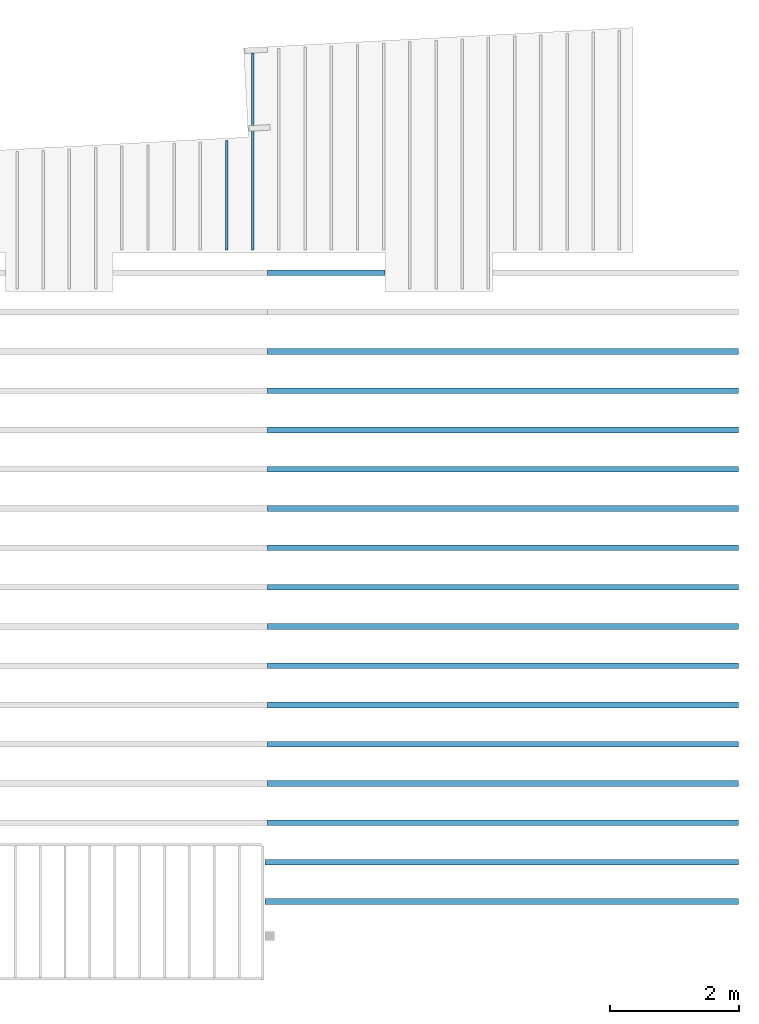
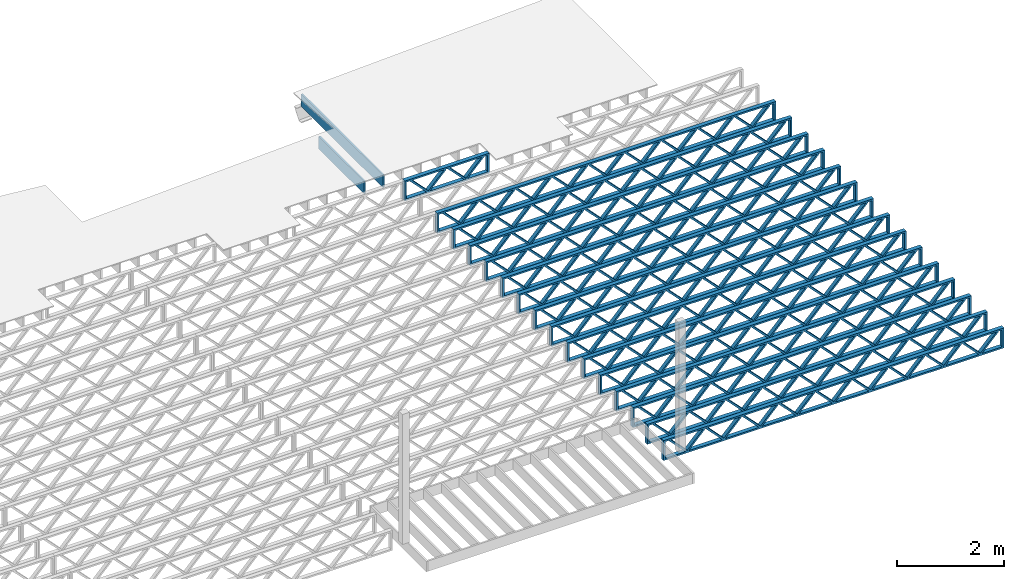
# One storey, part 11 of 13: 18 beams, 2 elements without a shape of their own.
"""IFC4 building model written with IfcOpenShell, lengths in feet."""

import ifcopenshell
import ifcopenshell.guid

model = None  # the IFC model being written
_history = None  # IfcOwnerHistory: only IFC2X3 demands one
_inside = {}  # id of a spatial element -> (the spatial element, [elements in it])
_under = {}  # id of a project, library or spatial element -> (it, [spatial elements below it])
_declared = {}  # id of a project -> (the project, [libraries it declares])
_typed = {}  # id of a type object -> (the type object, [elements of that type])
_made_of = {}  # id of a material, layer set ... -> (it, [elements and type objects made of it])


def new_model(schema):
    """Start an empty IFC model of exactly this schema.

    Asked for "IFC4X3", IfcOpenShell would pick the latest addendum, in which some entities
    have other attributes; the version numbers below select the first issue.
    IFC2X3 requires an IfcOwnerHistory on every rooted entity: one is made here for all.
    """
    global model, _history
    if schema == "IFC4X3":
        model = ifcopenshell.file(schema_version=(4, 3, 0, 0))
    else:
        model = ifcopenshell.file(schema=schema)
    _inside.clear()
    _under.clear()
    _declared.clear()
    _typed.clear()
    _made_of.clear()
    _history = None
    if model.schema == "IFC2X3":
        org = make("IfcOrganization", Name="unknown")
        user = make(
            "IfcPersonAndOrganization",
            ThePerson=make("IfcPerson", FamilyName="unknown"),
            TheOrganization=org,
        )
        app = make(
            "IfcApplication",
            ApplicationDeveloper=org,
            Version="unknown",
            ApplicationFullName="unknown",
            ApplicationIdentifier="unknown",
        )
        _history = make(
            "IfcOwnerHistory",
            OwningUser=user,
            OwningApplication=app,
            ChangeAction="ADDED",
            CreationDate=0,
        )
    return model


def make(cls, **values):
    """One entity of the class cls with the attributes given. An attribute that is None is left unset."""
    return model.create_entity(
        cls, **{name: value for name, value in values.items() if value is not None}
    )


def entity(cls, *values):
    """Any entity or typed value of the class cls, its attributes in the order of the schema. None: left unset."""
    e = model.create_entity(cls)
    for i, value in enumerate(values):
        if value is not None:
            e[i] = value
    return e


def rooted(cls, **values):
    """An entity with a GlobalId (a new one), such as an element, a storey or a relation."""
    return make(cls, GlobalId=ifcopenshell.guid.new(), OwnerHistory=_history, **values)


def si_unit(unit_type, name, prefix=None):
    """IfcSIUnit, for example si_unit("LENGTHUNIT", "METRE", prefix="MILLI")."""
    return make("IfcSIUnit", UnitType=unit_type, Prefix=prefix, Name=name)


def converted_unit(unit_type, name, factor, base, dimensions=None, offset=None):
    """IfcConversionBasedUnit, such as the inch: factor (a typed value) times the base unit."""
    return make(
        "IfcConversionBasedUnit"
        if offset is None
        else "IfcConversionBasedUnitWithOffset",
        ConversionOffset=offset,
        Dimensions=None
        if dimensions is None
        else entity("IfcDimensionalExponents", *dimensions),
        UnitType=unit_type,
        Name=name,
        ConversionFactor=make(
            "IfcMeasureWithUnit", ValueComponent=factor, UnitComponent=base
        ),
    )


def derived_unit(unit_type, elements):
    """IfcDerivedUnit: a product of units, each with its exponent."""
    return make(
        "IfcDerivedUnit",
        Elements=[
            make("IfcDerivedUnitElement", Unit=unit, Exponent=power)
            for unit, power in elements
        ],
        UnitType=unit_type,
    )


def assignment(units):
    """IfcUnitAssignment: the units of a project."""
    return None if units is None else make("IfcUnitAssignment", Units=units)


def point(xyz):
    """IfcCartesianPoint."""
    return None if xyz is None else make("IfcCartesianPoint", Coordinates=xyz)


def direction(xyz):
    """IfcDirection."""
    return None if xyz is None else make("IfcDirection", DirectionRatios=xyz)


def frame(location, z_axis=None, x_axis=None):
    """IfcAxis2Placement3D, a coordinate frame: its origin and axes. An axis left out is left unset."""
    return make(
        "IfcAxis2Placement3D",
        Location=point(location),
        Axis=direction(z_axis),
        RefDirection=direction(x_axis),
    )


def frame_2d(location, x_axis=None):
    """IfcAxis2Placement2D, a coordinate frame in the plane: its origin and x axis."""
    return make(
        "IfcAxis2Placement2D", Location=point(location), RefDirection=direction(x_axis)
    )


def origin():
    """The frame at (0, 0, 0) with its axes left unset."""
    return frame((0.0, 0.0, 0.0))


def origin_2d_with_axis():
    """The frame at (0, 0) in the plane with the x axis (1, 0) written out."""
    return frame_2d((0.0, 0.0), x_axis=(1.0, 0.0))


def place(relative_to, where):
    """IfcLocalPlacement: puts the frame where relative to a parent placement (None: the world)."""
    return make(
        "IfcLocalPlacement", PlacementRelTo=relative_to, RelativePlacement=where
    )


def context(
    kind, dimensions, precision=None, world=None, true_north=None, identifier=None
):
    """IfcGeometricRepresentationContext, for example the 3D "Model" context."""
    return make(
        "IfcGeometricRepresentationContext",
        ContextIdentifier=identifier,
        ContextType=kind,
        CoordinateSpaceDimension=dimensions,
        Precision=precision,
        WorldCoordinateSystem=world,
        TrueNorth=true_north,
    )


def subcontext(parent, identifier, kind, view, scale=None):
    """IfcGeometricRepresentationSubContext, for example "Body" below "Model"."""
    return make(
        "IfcGeometricRepresentationSubContext",
        ContextIdentifier=identifier,
        ContextType=kind,
        ParentContext=parent,
        TargetScale=scale,
        TargetView=view,
    )


def project(units=None, contexts=None):
    """IfcProject with its units and contexts."""
    return rooted(
        "IfcProject",
        Name="project",
        RepresentationContexts=contexts,
        UnitsInContext=assignment(units),
    )


def spatial(cls, under=None, at=None, **own):
    """A site, building, storey or space (cls), placed at a placement, below another one or the project."""
    s = rooted(cls, ObjectPlacement=at, **own)
    if under is not None:
        _under.setdefault(under.id(), (under, []))[1].append(s)
    return s


def profile(cls, at=None, kind="AREA", **sizes):
    """A parametric profile (cls). Its sizes go by their IFC names, for example OverallWidth=200.0."""
    return make(cls, ProfileType=kind, Position=at, **sizes)


def rectangle(**sizes):
    """IfcRectangleProfileDef."""
    return profile("IfcRectangleProfileDef", **sizes)


def extrude(swept, where, along, depth):
    """IfcExtrudedAreaSolid: the profile swept, set in the frame where, extruded along a direction by depth."""
    return make(
        "IfcExtrudedAreaSolid",
        SweptArea=swept,
        Position=where,
        ExtrudedDirection=direction(along),
        Depth=depth,
    )


def shape(context_of_items, identifier, shape_type, items):
    """IfcShapeRepresentation: the items that make up one representation, for example the "Body"."""
    return make(
        "IfcShapeRepresentation",
        ContextOfItems=context_of_items,
        RepresentationIdentifier=identifier,
        RepresentationType=shape_type,
        Items=items,
    )


def source(mapping_origin, context_of_items, identifier, shape_type, items):
    """IfcRepresentationMap: a shape defined once, which mapped items show again and again."""
    return make(
        "IfcRepresentationMap",
        MappingOrigin=mapping_origin,
        MappedRepresentation=shape(context_of_items, identifier, shape_type, items),
    )


def transform(
    local_origin,
    x_axis=None,
    y_axis=None,
    z_axis=None,
    scale=None,
    scale2=None,
    scale3=None,
    uniform=True,
):
    """IfcCartesianTransformationOperator3D, or its non-uniform kind. x_axis, y_axis, z_axis: its Axis1, 2, 3."""
    if uniform:
        return make(
            "IfcCartesianTransformationOperator3D",
            Axis1=direction(x_axis),
            Axis2=direction(y_axis),
            LocalOrigin=point(local_origin),
            Scale=scale,
            Axis3=direction(z_axis),
        )
    return make(
        "IfcCartesianTransformationOperator3DnonUniform",
        Axis1=direction(x_axis),
        Axis2=direction(y_axis),
        LocalOrigin=point(local_origin),
        Scale=scale,
        Axis3=direction(z_axis),
        Scale2=scale2,
        Scale3=scale3,
    )


def mapped(mapping_source, mapping_target):
    """IfcMappedItem: shows the shape of a source again, moved by a transform."""
    return make(
        "IfcMappedItem", MappingSource=mapping_source, MappingTarget=mapping_target
    )


def material(Name=None, Category=None):
    """IfcMaterial."""
    return make("IfcMaterial", Name=Name, Category=Category)


def material_profile(
    of_material, cross_section, Name=None, Category=None, Priority=None
):
    """IfcMaterialProfile: a cross section and its material."""
    return make(
        "IfcMaterialProfile",
        Name=Name,
        Material=of_material,
        Profile=cross_section,
        Priority=Priority,
        Category=Category,
    )


def profile_set(profiles, Name=None, composite=None):
    """IfcMaterialProfileSet."""
    return make(
        "IfcMaterialProfileSet",
        Name=Name,
        MaterialProfiles=profiles,
        CompositeProfile=composite,
    )


def profile_usage(for_profile_set, cardinal=None, extent=None):
    """IfcMaterialProfileSetUsage: how a profile set lies along its element."""
    return make(
        "IfcMaterialProfileSetUsage",
        ForProfileSet=for_profile_set,
        CardinalPoint=cardinal,
        ReferenceExtent=extent,
    )


def made_of(thing, what):
    """Note that an element or type object is made of a material, layer set ...; save() writes the relation."""
    if what is not None:
        _made_of.setdefault(what.id(), (what, []))[1].append(thing)
    return thing


def type_object(cls, material=None, **own):
    """A type object (cls), such as IfcWallType, which elements share."""
    return made_of(rooted(cls, **own), material)


def type_shapes(of_type, sources):
    """Give a type object the sources (RepresentationMaps) that its elements show as mapped items."""
    of_type.RepresentationMaps = sources


def element(
    cls,
    number,
    at=None,
    inside=None,
    cuts=None,
    type_object=None,
    material=None,
    context=None,
    identifier="Body",
    shape_type=None,
    held_by="IfcProductDefinitionShape",
    body=None,
    shapes=None,
    **own,
):
    """One element of the class cls, such as IfcWall. Its Tag is "e" and its number.

    at: its placement. inside: the storey or other place that contains it. cuts: it is an
    opening in that element (IfcRelVoidsElement). A single representation is given by context,
    identifier, shape_type and body (its items); several are given by shapes. held_by: the class
    of the entity that holds the representations. save() writes the other relations.
    """
    e = rooted(cls, Tag="e%d" % number, ObjectPlacement=at, **own)
    if body is not None:
        shapes = [shape(context, identifier, shape_type, body)]
    if shapes is not None:
        e.Representation = make(held_by, Representations=shapes)
    if inside is not None:
        _inside.setdefault(inside.id(), (inside, []))[1].append(e)
    if cuts is not None:
        rooted(
            "IfcRelVoidsElement", RelatingBuildingElement=cuts, RelatedOpeningElement=e
        )
    if type_object is not None:
        _typed.setdefault(type_object.id(), (type_object, []))[1].append(e)
    return made_of(e, material)


def aggregate(whole, parts):
    """IfcRelAggregates: a whole, such as a stair, and the parts it consists of."""
    return rooted("IfcRelAggregates", RelatingObject=whole, RelatedObjects=parts)


def save(model, path):
    """Write the relations noted so far, then the file.

    IfcRelAggregates (storeys below a building ...), IfcRelContainedInSpatialStructure (elements
    in a storey), IfcRelDefinesByType, IfcRelAssociatesMaterial and IfcRelDeclares: one each for
    every whole, place, type object, material and project.
    """
    for whole, parts in _under.values():
        aggregate(whole, parts)
    for where, things in _inside.values():
        rooted(
            "IfcRelContainedInSpatialStructure",
            RelatedElements=things,
            RelatingStructure=where,
        )
    for kind, things in _typed.values():
        rooted("IfcRelDefinesByType", RelatedObjects=things, RelatingType=kind)
    for what, things in _made_of.values():
        rooted("IfcRelAssociatesMaterial", RelatedObjects=things, RelatingMaterial=what)
    for by, libraries in _declared.values():
        rooted("IfcRelDeclares", RelatingContext=by, RelatedDefinitions=libraries)
    model.write(path)


model = new_model("IFC4")

# Units and contexts
model_context_1 = context("Model", 3, precision=0.0001, world=origin(), true_north=direction((6.12303176911189e-17, 1.0)))
model_context_2 = context("Model", 3, precision=0.0001, world=origin(), true_north=direction((6.12303176911189e-17, 1.0)))
body_context = subcontext(model_context_2, "Body", "Model", "MODEL_VIEW")
ifc_project = project(units=[converted_unit("LENGTHUNIT", "FOOT", entity("IfcRatioMeasure", 0.3048), si_unit("LENGTHUNIT", "METRE"), dimensions=[1, 0, 0, 0, 0, 0, 0]), converted_unit("AREAUNIT", "SQUARE FOOT", entity("IfcRatioMeasure", 0.09290304), si_unit("AREAUNIT", "SQUARE_METRE"), dimensions=[2, 0, 0, 0, 0, 0, 0]), converted_unit("VOLUMEUNIT", "CUBIC FOOT", entity("IfcRatioMeasure", 0.028316846592), si_unit("VOLUMEUNIT", "CUBIC_METRE"), dimensions=[3, 0, 0, 0, 0, 0, 0]), converted_unit("PLANEANGLEUNIT", "DEGREE", entity("IfcRatioMeasure", 0.0174532925199433), si_unit("PLANEANGLEUNIT", "RADIAN"), dimensions=[0, 0, 0, 0, 0, 0, 0]), si_unit("MASSUNIT", "GRAM", prefix="KILO"), derived_unit("MASSDENSITYUNIT", [(si_unit("MASSUNIT", "GRAM", prefix="KILO"), 1), (si_unit("LENGTHUNIT", "METRE"), -3)]), derived_unit("MOMENTOFINERTIAUNIT", [(si_unit("LENGTHUNIT", "METRE"), 4)]), si_unit("TIMEUNIT", "SECOND"), si_unit("FREQUENCYUNIT", "HERTZ"), si_unit("THERMODYNAMICTEMPERATUREUNIT", "DEGREE_CELSIUS"), derived_unit("THERMALTRANSMITTANCEUNIT", [(si_unit("MASSUNIT", "GRAM", prefix="KILO"), 1), (si_unit("THERMODYNAMICTEMPERATUREUNIT", "KELVIN"), -1), (si_unit("TIMEUNIT", "SECOND"), -3)]), derived_unit("VOLUMETRICFLOWRATEUNIT", [(si_unit("LENGTHUNIT", "METRE"), 3), (si_unit("TIMEUNIT", "SECOND"), -1)]), si_unit("ELECTRICCURRENTUNIT", "AMPERE"), si_unit("ELECTRICVOLTAGEUNIT", "VOLT"), si_unit("POWERUNIT", "WATT"), si_unit("FORCEUNIT", "NEWTON"), si_unit("ILLUMINANCEUNIT", "LUX"), si_unit("LUMINOUSFLUXUNIT", "LUMEN"), si_unit("LUMINOUSINTENSITYUNIT", "CANDELA"), derived_unit("USERDEFINED", [(si_unit("MASSUNIT", "GRAM", prefix="KILO"), -1), (si_unit("LENGTHUNIT", "METRE"), -2), (si_unit("TIMEUNIT", "SECOND"), 3), (si_unit("LUMINOUSFLUXUNIT", "LUMEN"), 1)]), derived_unit("LINEARVELOCITYUNIT", [(si_unit("LENGTHUNIT", "METRE"), 1), (si_unit("TIMEUNIT", "SECOND"), -1)]), si_unit("PRESSUREUNIT", "PASCAL"), derived_unit("USERDEFINED", [(si_unit("LENGTHUNIT", "METRE"), -2), (si_unit("MASSUNIT", "GRAM", prefix="KILO"), 1), (si_unit("TIMEUNIT", "SECOND"), -2)]), derived_unit("LINEARFORCEUNIT", [(si_unit("MASSUNIT", "GRAM", prefix="KILO"), 1), (si_unit("LENGTHUNIT", "METRE"), 1), (si_unit("TIMEUNIT", "SECOND"), -2), (si_unit("LENGTHUNIT", "METRE"), -1)]), derived_unit("PLANARFORCEUNIT", [(si_unit("MASSUNIT", "GRAM", prefix="KILO"), 1), (si_unit("LENGTHUNIT", "METRE"), 1), (si_unit("TIMEUNIT", "SECOND"), -2), (si_unit("LENGTHUNIT", "METRE"), -2)])], contexts=[model_context_1])

# Site, building, storey
site_placement = place(None, origin())
site = spatial("IfcSite", under=ifc_project, at=site_placement, CompositionType="ELEMENT")
building_placement = place(site_placement, origin())
building = spatial("IfcBuilding", under=site, at=building_placement, CompositionType="ELEMENT")
storey_placement = place(building_placement, frame((0.0, 0.0, 21.46875)))
storey = spatial("IfcBuildingStorey", under=building, at=storey_placement, Name="3RD FLOOR", CompositionType="ELEMENT", Elevation=21.46875)

# Assembly, beams
assembly_1_placement = place(storey_placement, origin())
assembly_1 = element("IfcElementAssembly", 1, at=assembly_1_placement, inside=storey, Name="Structural Beam System:Structural Framing System", ObjectType="Structural Beam System:Structural Framing System", AssemblyPlace="NOTDEFINED", PredefinedType="BEAM_GRID")
ifc_material_1 = material(Name="WOOD TRUSS", Category="Materials")
ifc_material_profile_1 = material_profile(ifc_material_1, rectangle(XDim=1.73473973950632, YDim=0.125, at=frame_2d((-1.11022302462516e-16, 8.32667268468867e-17), x_axis=(1.0, 0.0))))
ifc_material_profile_2 = material_profile(ifc_material_1, rectangle(XDim=1.73473973950633, YDim=0.125, at=frame_2d((-1.11022302462516e-16, 8.32667268468867e-17), x_axis=(1.0, 0.0))))
ifc_material_profile_3 = material_profile(ifc_material_1, rectangle(XDim=1.73473973950632, YDim=0.125, at=frame_2d((-5.55111512312578e-17, 1.38777878078145e-16), x_axis=(1.0, 0.0))))
ifc_material_profile_4 = material_profile(ifc_material_1, rectangle(XDim=1.73473973950633, YDim=0.125, at=frame_2d((-1.11022302462516e-16, 8.32667268468867e-17), x_axis=(1.0, 0.0))))
ifc_material_profile_5 = material_profile(ifc_material_1, rectangle(XDim=1.73473973950632, YDim=0.125, at=frame_2d((-1.11022302462516e-16, 8.32667268468867e-17), x_axis=(1.0, 0.0))))
ifc_material_profile_6 = material_profile(ifc_material_1, rectangle(XDim=1.73473973950633, YDim=0.125, at=frame_2d((-2.77555756156289e-16, 3.05311331771918e-16), x_axis=(1.0, 0.0))))
ifc_material_profile_7 = material_profile(ifc_material_1, rectangle(XDim=1.73473973950632, YDim=0.124999999999999, at=frame_2d((-3.88578058618805e-16, -2.4980018054066e-16), x_axis=(1.0, 0.0))))
ifc_material_profile_8 = material_profile(ifc_material_1, rectangle(XDim=1.73473973950633, YDim=0.125, at=frame_2d((2.77555756156289e-16, -3.05311331771918e-16), x_axis=(1.0, 0.0))))
ifc_material_profile_9 = material_profile(ifc_material_1, rectangle(XDim=1.73473973950632, YDim=0.124999999999999, at=frame_2d((-1.11022302462516e-16, 8.32667268468867e-17), x_axis=(1.0, 0.0))))
ifc_material_profile_10 = material_profile(ifc_material_1, rectangle(XDim=1.73473973950633, YDim=0.125, at=origin_2d_with_axis()))
ifc_material_profile_11 = material_profile(ifc_material_1, rectangle(XDim=0.124999999999982, YDim=0.291666666666668, at=origin_2d_with_axis()))
ifc_material_profile_12 = material_profile(ifc_material_1, rectangle(XDim=0.124999999999932, YDim=0.291666666666664, at=origin_2d_with_axis()))
ifc_material_profile_13 = material_profile(ifc_material_1, rectangle(XDim=1.25000000000002, YDim=0.29166666666667, at=origin_2d_with_axis()))
ifc_material_profile_14 = material_profile(ifc_material_1, rectangle(XDim=1.25000000000004, YDim=0.291666666666667, at=origin_2d_with_axis()))
ifc_profile_set_1 = profile_set([ifc_material_profile_1, ifc_material_profile_2, ifc_material_profile_3, ifc_material_profile_4, ifc_material_profile_5, ifc_material_profile_6, ifc_material_profile_7, ifc_material_profile_8, ifc_material_profile_9, ifc_material_profile_10, ifc_material_profile_11, ifc_material_profile_12, ifc_material_profile_13, ifc_material_profile_14])
ifc_profile_usage_1 = profile_usage(ifc_profile_set_1, cardinal=8)
beam_type_1 = type_object("IfcBeamType", PredefinedType="BEAM", material=ifc_profile_set_1)
shared_shape_1 = source(origin(), body_context, "Body", "SweptSolid", [
    extrude(rectangle(XDim=1.73473973950632, YDim=0.124999999999999, at=frame_2d((5.55111512312578e-16, 7.21644966006352e-16), x_axis=(1.0, 0.0))), frame((8.42202085580899, -0.145833333333334, 0.0), z_axis=(0.0, 1.0, 0.0), x_axis=(0.693383046997606, 0.0, 0.720569184836762)), (0.0, 0.0, 1.0), 0.291666666666667),
    extrude(rectangle(XDim=1.73473973950633, YDim=0.125, at=origin_2d_with_axis()), frame((7.17173498213572, -0.145833333333334, 0.0), z_axis=(0.0, 1.0, 0.0), x_axis=(0.69338304699761, 0.0, -0.720569184836758)), (0.0, 0.0, 1.0), 0.291666666666666),
    extrude(rectangle(XDim=1.73473973950632, YDim=0.124999999999999, at=frame_2d((-1.11022302462516e-16, 8.32667268468867e-17), x_axis=(1.0, 0.0))), frame((5.82306154948498, -0.145833333333334, 0.0), z_axis=(0.0, 1.0, 0.0), x_axis=(0.693383046997606, 0.0, 0.720569184836762)), (0.0, 0.0, 1.0), 0.291666666666667),
    extrude(rectangle(XDim=1.73473973950633, YDim=0.125, at=origin_2d_with_axis()), frame((4.57277567581171, -0.145833333333334, 0.0), z_axis=(0.0, 1.0, 0.0), x_axis=(0.69338304699761, 0.0, -0.720569184836758)), (0.0, 0.0, 1.0), 0.291666666666666),
    extrude(rectangle(XDim=1.73473973950632, YDim=0.125, at=frame_2d((2.22044604925031e-16, 3.88578058618805e-16), x_axis=(1.0, 0.0))), frame((3.22410224316097, -0.145833333333334, 0.0), z_axis=(0.0, 1.0, 0.0), x_axis=(0.693383046997606, 0.0, 0.720569184836762)), (0.0, 0.0, 1.0), 0.291666666666667),
    extrude(rectangle(XDim=1.73473973950633, YDim=0.125, at=frame_2d((-1.11022302462516e-16, 8.32667268468867e-17), x_axis=(1.0, 0.0))), frame((1.9738163694877, -0.145833333333334, 0.0), z_axis=(0.0, 1.0, 0.0), x_axis=(0.69338304699761, 0.0, -0.720569184836758)), (0.0, 0.0, 1.0), 0.291666666666667),
    extrude(rectangle(XDim=1.73473973950632, YDim=0.125, at=frame_2d((-5.55111512312578e-17, 1.38777878078145e-16), x_axis=(1.0, 0.0))), frame((0.625142936836964, -0.145833333333334, 0.0), z_axis=(0.0, 1.0, 0.0), x_axis=(0.693383046997606, 0.0, 0.720569184836762)), (0.0, 0.0, 1.0), 0.291666666666667),
    extrude(rectangle(XDim=1.73473973950633, YDim=0.125, at=frame_2d((-1.11022302462516e-16, 8.32667268468867e-17), x_axis=(1.0, 0.0))), frame((-0.625142936836306, -0.145833333333334, 0.0), z_axis=(0.0, 1.0, 0.0), x_axis=(0.69338304699761, 0.0, -0.720569184836758)), (0.0, 0.0, 1.0), 0.291666666666667),
    extrude(rectangle(XDim=1.73473973950632, YDim=0.125, at=frame_2d((-1.11022302462516e-16, 8.32667268468867e-17), x_axis=(1.0, 0.0))), frame((-1.97381636948704, -0.145833333333334, 0.0), z_axis=(0.0, 1.0, 0.0), x_axis=(0.693383046997606, 0.0, 0.720569184836762)), (0.0, 0.0, 1.0), 0.291666666666667),
    extrude(rectangle(XDim=1.73473973950633, YDim=0.125, at=origin_2d_with_axis()), frame((-3.22410224316031, -0.145833333333334, 0.0), z_axis=(0.0, 1.0, 0.0), x_axis=(0.69338304699761, 0.0, -0.720569184836758)), (0.0, 0.0, 1.0), 0.291666666666667),
    extrude(rectangle(XDim=1.73473973950632, YDim=0.124999999999999, at=frame_2d((-1.11022302462516e-16, 8.32667268468867e-17), x_axis=(1.0, 0.0))), frame((-4.57277567581105, -0.145833333333334, 0.0), z_axis=(0.0, 1.0, 0.0), x_axis=(0.693383046997606, 0.0, 0.720569184836762)), (0.0, 0.0, 1.0), 0.291666666666667),
    extrude(rectangle(XDim=1.73473973950633, YDim=0.125, at=origin_2d_with_axis()), frame((-5.82306154948432, -0.145833333333334, 0.0), z_axis=(0.0, 1.0, 0.0), x_axis=(0.69338304699761, 0.0, -0.720569184836758)), (0.0, 0.0, 1.0), 0.291666666666666),
    extrude(rectangle(XDim=1.73473973950632, YDim=0.124999999999999, at=frame_2d((-1.11022302462516e-16, 8.32667268468867e-17), x_axis=(1.0, 0.0))), frame((-7.17173498213506, -0.145833333333334, 0.0), z_axis=(0.0, 1.0, 0.0), x_axis=(0.693383046997606, 0.0, 0.720569184836762)), (0.0, 0.0, 1.0), 0.291666666666667),
    extrude(rectangle(XDim=1.73473973950633, YDim=0.125, at=frame_2d((-2.77555756156289e-16, 3.05311331771918e-16), x_axis=(1.0, 0.0))), frame((-8.42202085580833, -0.145833333333334, 0.0), z_axis=(0.0, 1.0, 0.0), x_axis=(0.69338304699761, 0.0, -0.720569184836758)), (0.0, 0.0, 1.0), 0.291666666666666),
    extrude(rectangle(XDim=1.73473973950632, YDim=0.125, at=frame_2d((-7.21644966006352e-16, -5.55111512312578e-16), x_axis=(1.0, 0.0))), frame((11.020980162133, -0.145833333333334, 0.0), z_axis=(0.0, 1.0, 0.0), x_axis=(0.693383046997606, 0.0, 0.720569184836762)), (0.0, 0.0, 1.0), 0.291666666666667),
    extrude(rectangle(XDim=1.73473973950633, YDim=0.125, at=origin_2d_with_axis()), frame((9.77069428845972, -0.145833333333334, 0.0), z_axis=(0.0, 1.0, 0.0), x_axis=(0.69338304699761, 0.0, -0.720569184836758)), (0.0, 0.0, 1.0), 0.291666666666666),
    extrude(rectangle(XDim=1.73473973950632, YDim=0.125, at=frame_2d((-5.55111512312578e-17, 8.32667268468867e-17), x_axis=(1.0, 0.0))), frame((-9.77069428845906, -0.145833333333334, 0.0), z_axis=(0.0, 1.0, 0.0), x_axis=(0.693383046997606, 0.0, 0.720569184836762)), (0.0, 0.0, 1.0), 0.291666666666667),
    extrude(rectangle(XDim=1.73473973950633, YDim=0.125, at=origin_2d_with_axis()), frame((-11.0209801621323, -0.145833333333334, 0.0), z_axis=(0.0, 1.0, 0.0), x_axis=(0.69338304699761, 0.0, -0.720569184836758)), (0.0, 0.0, 1.0), 0.291666666666666),
    extrude(rectangle(XDim=0.124999999999982, YDim=0.291666666666668, at=origin_2d_with_axis()), frame((-12.0625038919626, 0.0, 0.687500000000054), z_axis=(1.0, 0.0, 0.0), x_axis=(0.0, 0.0, -1.0)), (0.0, 0.0, 1.0), 24.1250077839252),
    extrude(rectangle(XDim=0.124999999999932, YDim=0.291666666666664, at=origin_2d_with_axis()), frame((-12.0625038919624, 0.0, -0.687499999999984), z_axis=(1.0, 0.0, 0.0), x_axis=(0.0, 0.0, -1.0)), (0.0, 0.0, 1.0), 24.125007783925),
    extrude(rectangle(XDim=1.25000000000002, YDim=0.29166666666667, at=origin_2d_with_axis()), frame((11.9375038919626, 0.0, 0.0), z_axis=(1.0, 0.0, 0.0), x_axis=(0.0, 0.0, -1.0)), (0.0, 0.0, 1.0), 0.12500000000002),
    extrude(rectangle(XDim=1.25000000000004, YDim=0.291666666666667, at=origin_2d_with_axis()), frame((-12.0625038919626, 0.0, 0.0), z_axis=(1.0, 0.0, 0.0), x_axis=(0.0, 0.0, -1.0)), (0.0, 0.0, 1.0), 0.125000000000023),
])
type_shapes(beam_type_1, [shared_shape_1])
beam_1_placement = place(assembly_1_placement, frame((-152.467323260299, 927.861934882651, -0.947916666657864), z_axis=(0.0, 0.0, 1.0), x_axis=(-1.0, 0.0, 0.0)))
beam_1 = element("IfcBeam", 2, at=beam_1_placement, type_object=beam_type_1, material=ifc_profile_usage_1, PredefinedType="BEAM", context=body_context, shape_type="MappedRepresentation", body=[
    mapped(shared_shape_1, transform((0.0, 0.0, 0.0), scale=1.0)),
])
ifc_profile_usage_2 = profile_usage(ifc_profile_set_1, cardinal=8)
beam_2_placement = place(assembly_1_placement, frame((-152.467323260299, 925.861934882651, -0.947916666657864), z_axis=(0.0, 0.0, 1.0), x_axis=(-1.0, 0.0, 0.0)))
beam_2 = element("IfcBeam", 3, at=beam_2_placement, type_object=beam_type_1, material=ifc_profile_usage_2, PredefinedType="BEAM", context=body_context, shape_type="MappedRepresentation", body=[
    mapped(shared_shape_1, transform((0.0, 0.0, 0.0), scale=1.0)),
])

assembly_2_placement = place(storey_placement, origin())
assembly_2 = element("IfcElementAssembly", 4, at=assembly_2_placement, inside=storey, Name="Structural Beam System:Structural Framing System", ObjectType="Structural Beam System:Structural Framing System", AssemblyPlace="NOTDEFINED", PredefinedType="BEAM_GRID")
ifc_material_2 = material(Category="Materials")
ifc_material_profile_15 = material_profile(ifc_material_2, rectangle(XDim=0.9375, YDim=0.125000000000011, at=origin_2d_with_axis()))
ifc_profile_set_2 = profile_set([ifc_material_profile_15])
ifc_profile_usage_3 = profile_usage(ifc_profile_set_2, cardinal=8)
beam_type_2 = type_object("IfcBeamType", PredefinedType="BEAM", material=ifc_profile_set_2)
shared_shape_2 = source(origin(), body_context, "Body", "SweptSolid", [
    extrude(rectangle(XDim=0.9375, YDim=0.125000000000011, at=origin_2d_with_axis()), frame((-2.78242570162547, 0.0, 0.0), z_axis=(1.0, 0.0, 0.0), x_axis=(0.0, 0.0, -1.0)), (0.0, 0.0, 1.0), 5.56485140325094),
])
type_shapes(beam_type_2, [shared_shape_2])
beam_3_placement = place(assembly_2_placement, frame((-166.477622729298, 961.811024684039, -0.729166666666714), z_axis=(0.0, 0.0, 1.0), x_axis=(0.0, 1.0, 0.0)))
beam_3 = element("IfcBeam", 5, at=beam_3_placement, type_object=beam_type_2, material=ifc_profile_usage_3, PredefinedType="BEAM", context=body_context, shape_type="MappedRepresentation", body=[
    mapped(shared_shape_2, transform((0.0, 0.0, 0.0), scale=1.0)),
])
ifc_profile_usage_4 = profile_usage(ifc_profile_set_2, cardinal=8)
beam_type_3 = type_object("IfcBeamType", PredefinedType="BEAM", material=ifc_profile_set_2)
shared_shape_3 = source(origin(), body_context, "Body", "SweptSolid", [
    extrude(rectangle(XDim=0.9375, YDim=0.125000000000011, at=origin_2d_with_axis()), frame((-5.12102117510278, 0.0, 0.0), z_axis=(1.0, 0.0, 0.0), x_axis=(0.0, 0.0, -1.0)), (0.0, 0.0, 1.0), 10.0208014833547),
])
type_shapes(beam_type_3, [shared_shape_3])
beam_4_placement = place(assembly_2_placement, frame((-165.144289386034, 964.149620416103, -0.729166666666714), z_axis=(0.0, 0.0, 1.0), x_axis=(0.0, 1.0, 0.0)))
beam_4 = element("IfcBeam", 6, at=beam_4_placement, type_object=beam_type_3, material=ifc_profile_usage_4, PredefinedType="BEAM", context=body_context, shape_type="MappedRepresentation", body=[
    mapped(shared_shape_3, transform((0.0, 0.0, 0.0), scale=1.0)),
])
aggregate(assembly_2, [beam_3, beam_4])

# Beam
ifc_profile_usage_5 = profile_usage(ifc_profile_set_1, cardinal=8)
beam_type_4 = type_object("IfcBeamType", PredefinedType="BEAM", material=ifc_profile_set_1)
shared_shape_4 = source(origin(), body_context, "Body", "SweptSolid", [
    extrude(rectangle(XDim=1.73473973950632, YDim=0.124999999999999, at=frame_2d((5.55111512312578e-16, 7.21644966006352e-16), x_axis=(1.0, 0.0))), frame((8.37514585578398, -0.145833333333334, 0.0), z_axis=(0.0, 1.0, 0.0), x_axis=(0.693383046997606, 0.0, 0.720569184836762)), (0.0, 0.0, 1.0), 0.291666666666667),
    extrude(rectangle(XDim=1.73473973950633, YDim=0.125, at=origin_2d_with_axis()), frame((7.12485998211071, -0.145833333333334, 0.0), z_axis=(0.0, 1.0, 0.0), x_axis=(0.69338304699761, 0.0, -0.720569184836758)), (0.0, 0.0, 1.0), 0.291666666666666),
    extrude(rectangle(XDim=1.73473973950632, YDim=0.124999999999999, at=frame_2d((-1.11022302462516e-16, 8.32667268468867e-17), x_axis=(1.0, 0.0))), frame((5.79181154946831, -0.145833333333334, 0.0), z_axis=(0.0, 1.0, 0.0), x_axis=(0.693383046997606, 0.0, 0.720569184836762)), (0.0, 0.0, 1.0), 0.291666666666667),
    extrude(rectangle(XDim=1.73473973950633, YDim=0.125, at=origin_2d_with_axis()), frame((4.54152567579504, -0.145833333333334, 0.0), z_axis=(0.0, 1.0, 0.0), x_axis=(0.69338304699761, 0.0, -0.720569184836758)), (0.0, 0.0, 1.0), 0.291666666666666),
    extrude(rectangle(XDim=1.73473973950632, YDim=0.125, at=frame_2d((2.22044604925031e-16, 3.88578058618805e-16), x_axis=(1.0, 0.0))), frame((3.20847724315264, -0.145833333333334, 0.0), z_axis=(0.0, 1.0, 0.0), x_axis=(0.693383046997606, 0.0, 0.720569184836762)), (0.0, 0.0, 1.0), 0.291666666666667),
    extrude(rectangle(XDim=1.73473973950633, YDim=0.125, at=frame_2d((-1.11022302462516e-16, 8.32667268468867e-17), x_axis=(1.0, 0.0))), frame((1.95819136947937, -0.145833333333334, 0.0), z_axis=(0.0, 1.0, 0.0), x_axis=(0.69338304699761, 0.0, -0.720569184836758)), (0.0, 0.0, 1.0), 0.291666666666667),
    extrude(rectangle(XDim=1.73473973950632, YDim=0.125, at=frame_2d((-5.55111512312578e-17, 1.38777878078145e-16), x_axis=(1.0, 0.0))), frame((0.625142936836964, -0.145833333333334, 0.0), z_axis=(0.0, 1.0, 0.0), x_axis=(0.693383046997606, 0.0, 0.720569184836762)), (0.0, 0.0, 1.0), 0.291666666666667),
    extrude(rectangle(XDim=1.73473973950633, YDim=0.125, at=frame_2d((-1.11022302462516e-16, 8.32667268468867e-17), x_axis=(1.0, 0.0))), frame((-0.625142936836306, -0.145833333333334, 0.0), z_axis=(0.0, 1.0, 0.0), x_axis=(0.69338304699761, 0.0, -0.720569184836758)), (0.0, 0.0, 1.0), 0.291666666666667),
    extrude(rectangle(XDim=1.73473973950632, YDim=0.125, at=frame_2d((-1.11022302462516e-16, 8.32667268468867e-17), x_axis=(1.0, 0.0))), frame((-1.95819136947871, -0.145833333333334, 0.0), z_axis=(0.0, 1.0, 0.0), x_axis=(0.693383046997606, 0.0, 0.720569184836762)), (0.0, 0.0, 1.0), 0.291666666666667),
    extrude(rectangle(XDim=1.73473973950633, YDim=0.125, at=origin_2d_with_axis()), frame((-3.20847724315198, -0.145833333333334, 0.0), z_axis=(0.0, 1.0, 0.0), x_axis=(0.69338304699761, 0.0, -0.720569184836758)), (0.0, 0.0, 1.0), 0.291666666666667),
    extrude(rectangle(XDim=1.73473973950632, YDim=0.124999999999999, at=frame_2d((-1.11022302462516e-16, 8.32667268468867e-17), x_axis=(1.0, 0.0))), frame((-4.54152567579438, -0.145833333333334, 0.0), z_axis=(0.0, 1.0, 0.0), x_axis=(0.693383046997606, 0.0, 0.720569184836762)), (0.0, 0.0, 1.0), 0.291666666666667),
    extrude(rectangle(XDim=1.73473973950633, YDim=0.125, at=origin_2d_with_axis()), frame((-5.79181154946765, -0.145833333333334, 0.0), z_axis=(0.0, 1.0, 0.0), x_axis=(0.69338304699761, 0.0, -0.720569184836758)), (0.0, 0.0, 1.0), 0.291666666666666),
    extrude(rectangle(XDim=1.73473973950632, YDim=0.124999999999999, at=frame_2d((-1.11022302462516e-16, 8.32667268468867e-17), x_axis=(1.0, 0.0))), frame((-7.12485998211005, -0.145833333333334, 0.0), z_axis=(0.0, 1.0, 0.0), x_axis=(0.693383046997606, 0.0, 0.720569184836762)), (0.0, 0.0, 1.0), 0.291666666666667),
    extrude(rectangle(XDim=1.73473973950633, YDim=0.125, at=frame_2d((-2.77555756156289e-16, 3.05311331771918e-16), x_axis=(1.0, 0.0))), frame((-8.37514585578332, -0.145833333333334, 0.0), z_axis=(0.0, 1.0, 0.0), x_axis=(0.69338304699761, 0.0, -0.720569184836758)), (0.0, 0.0, 1.0), 0.291666666666666),
    extrude(rectangle(XDim=1.73473973950632, YDim=0.125, at=frame_2d((-7.21644966006352e-16, -5.55111512312578e-16), x_axis=(1.0, 0.0))), frame((10.9584801620997, -0.145833333333334, 0.0), z_axis=(0.0, 1.0, 0.0), x_axis=(0.693383046997606, 0.0, 0.720569184836762)), (0.0, 0.0, 1.0), 0.291666666666667),
    extrude(rectangle(XDim=1.73473973950633, YDim=0.125, at=origin_2d_with_axis()), frame((9.70819428842638, -0.145833333333334, 0.0), z_axis=(0.0, 1.0, 0.0), x_axis=(0.69338304699761, 0.0, -0.720569184836758)), (0.0, 0.0, 1.0), 0.291666666666666),
    extrude(rectangle(XDim=1.73473973950632, YDim=0.125, at=frame_2d((-5.55111512312578e-17, 8.32667268468867e-17), x_axis=(1.0, 0.0))), frame((-9.70819428842572, -0.145833333333334, 0.0), z_axis=(0.0, 1.0, 0.0), x_axis=(0.693383046997606, 0.0, 0.720569184836762)), (0.0, 0.0, 1.0), 0.291666666666667),
    extrude(rectangle(XDim=1.73473973950633, YDim=0.125, at=origin_2d_with_axis()), frame((-10.958480162099, -0.145833333333334, 0.0), z_axis=(0.0, 1.0, 0.0), x_axis=(0.69338304699761, 0.0, -0.720569184836758)), (0.0, 0.0, 1.0), 0.291666666666666),
    extrude(rectangle(XDim=0.124999999999982, YDim=0.291666666666668, at=origin_2d_with_axis()), frame((-12.0000038919293, 0.0, 0.687500000000054), z_axis=(1.0, 0.0, 0.0), x_axis=(0.0, 0.0, -1.0)), (0.0, 0.0, 1.0), 24.0000077838585),
    extrude(rectangle(XDim=0.124999999999932, YDim=0.291666666666664, at=origin_2d_with_axis()), frame((-12.0000038919291, 0.0, -0.687499999999984), z_axis=(1.0, 0.0, 0.0), x_axis=(0.0, 0.0, -1.0)), (0.0, 0.0, 1.0), 24.0000077838583),
    extrude(rectangle(XDim=1.25000000000002, YDim=0.29166666666667, at=origin_2d_with_axis()), frame((11.8750038919292, 0.0, 0.0), z_axis=(1.0, 0.0, 0.0), x_axis=(0.0, 0.0, -1.0)), (0.0, 0.0, 1.0), 0.12500000000002),
    extrude(rectangle(XDim=1.25000000000004, YDim=0.291666666666667, at=origin_2d_with_axis()), frame((-12.0000038919293, 0.0, 0.0), z_axis=(1.0, 0.0, 0.0), x_axis=(0.0, 0.0, -1.0)), (0.0, 0.0, 1.0), 0.125000000000023),
])
type_shapes(beam_type_4, [shared_shape_4])
beam_5_placement = place(assembly_1_placement, frame((-152.404823260266, 931.861934882651, -0.947916666657864), z_axis=(0.0, 0.0, 1.0), x_axis=(-1.0, 0.0, 0.0)))
beam_5 = element("IfcBeam", 7, at=beam_5_placement, type_object=beam_type_4, material=ifc_profile_usage_5, PredefinedType="BEAM", context=body_context, shape_type="MappedRepresentation", body=[
    mapped(shared_shape_4, transform((0.0, 0.0, 0.0), scale=1.0)),
])

ifc_profile_usage_6 = profile_usage(ifc_profile_set_1, cardinal=8)
beam_6_placement = place(assembly_1_placement, frame((-152.404823260266, 941.861934882651, -0.947916666657864), z_axis=(0.0, 0.0, 1.0), x_axis=(-1.0, 0.0, 0.0)))
beam_6 = element("IfcBeam", 8, at=beam_6_placement, type_object=beam_type_4, material=ifc_profile_usage_6, PredefinedType="BEAM", context=body_context, shape_type="MappedRepresentation", body=[
    mapped(shared_shape_4, transform((0.0, 0.0, 0.0), scale=1.0)),
])

ifc_profile_usage_7 = profile_usage(ifc_profile_set_1, cardinal=8)
beam_7_placement = place(assembly_1_placement, frame((-152.404823260266, 943.861934882651, -0.947916666657864), z_axis=(0.0, 0.0, 1.0), x_axis=(-1.0, 0.0, 0.0)))
beam_7 = element("IfcBeam", 9, at=beam_7_placement, type_object=beam_type_4, material=ifc_profile_usage_7, PredefinedType="BEAM", context=body_context, shape_type="MappedRepresentation", body=[
    mapped(shared_shape_4, transform((0.0, 0.0, 0.0), scale=1.0)),
])

ifc_profile_usage_8 = profile_usage(ifc_profile_set_1, cardinal=8)
beam_8_placement = place(assembly_1_placement, frame((-152.404823260266, 945.861934882651, -0.947916666657864), z_axis=(0.0, 0.0, 1.0), x_axis=(-1.0, 0.0, 0.0)))
beam_8 = element("IfcBeam", 10, at=beam_8_placement, type_object=beam_type_4, material=ifc_profile_usage_8, PredefinedType="BEAM", context=body_context, shape_type="MappedRepresentation", body=[
    mapped(shared_shape_4, transform((0.0, 0.0, 0.0), scale=1.0)),
])

ifc_profile_usage_9 = profile_usage(ifc_profile_set_1, cardinal=8)
beam_9_placement = place(assembly_1_placement, frame((-152.404823260266, 947.861934882651, -0.947916666657864), z_axis=(0.0, 0.0, 1.0), x_axis=(-1.0, 0.0, 0.0)))
beam_9 = element("IfcBeam", 11, at=beam_9_placement, type_object=beam_type_4, material=ifc_profile_usage_9, PredefinedType="BEAM", context=body_context, shape_type="MappedRepresentation", body=[
    mapped(shared_shape_4, transform((0.0, 0.0, 0.0), scale=1.0)),
])

ifc_profile_usage_10 = profile_usage(ifc_profile_set_1, cardinal=8)
beam_10_placement = place(assembly_1_placement, frame((-152.404823260266, 949.861934882651, -0.947916666657864), z_axis=(0.0, 0.0, 1.0), x_axis=(-1.0, 0.0, 0.0)))
beam_10 = element("IfcBeam", 12, at=beam_10_placement, type_object=beam_type_4, material=ifc_profile_usage_10, PredefinedType="BEAM", context=body_context, shape_type="MappedRepresentation", body=[
    mapped(shared_shape_4, transform((0.0, 0.0, 0.0), scale=1.0)),
])

ifc_profile_usage_11 = profile_usage(ifc_profile_set_1, cardinal=8)
beam_11_placement = place(assembly_1_placement, frame((-152.404823260266, 951.861934882651, -0.947916666657864), z_axis=(0.0, 0.0, 1.0), x_axis=(-1.0, 0.0, 0.0)))
beam_11 = element("IfcBeam", 13, at=beam_11_placement, type_object=beam_type_4, material=ifc_profile_usage_11, PredefinedType="BEAM", context=body_context, shape_type="MappedRepresentation", body=[
    mapped(shared_shape_4, transform((0.0, 0.0, 0.0), scale=1.0)),
])

ifc_profile_usage_12 = profile_usage(ifc_profile_set_1, cardinal=8)
beam_12_placement = place(assembly_1_placement, frame((-152.404823260266, 953.861934882651, -0.947916666657864), z_axis=(0.0, 0.0, 1.0), x_axis=(-1.0, 0.0, 0.0)))
beam_12 = element("IfcBeam", 14, at=beam_12_placement, type_object=beam_type_4, material=ifc_profile_usage_12, PredefinedType="BEAM", context=body_context, shape_type="MappedRepresentation", body=[
    mapped(shared_shape_4, transform((0.0, 0.0, 0.0), scale=1.0)),
])

ifc_profile_usage_13 = profile_usage(ifc_profile_set_1, cardinal=8)
beam_13_placement = place(assembly_1_placement, frame((-152.404823260266, 939.861934882651, -0.947916666657864), z_axis=(0.0, 0.0, 1.0), x_axis=(-1.0, 0.0, 0.0)))
beam_13 = element("IfcBeam", 15, at=beam_13_placement, type_object=beam_type_4, material=ifc_profile_usage_13, PredefinedType="BEAM", context=body_context, shape_type="MappedRepresentation", body=[
    mapped(shared_shape_4, transform((0.0, 0.0, 0.0), scale=1.0)),
])

ifc_profile_usage_14 = profile_usage(ifc_profile_set_1, cardinal=8)
beam_14_placement = place(assembly_1_placement, frame((-152.404823260266, 937.861934882651, -0.947916666657864), z_axis=(0.0, 0.0, 1.0), x_axis=(-1.0, 0.0, 0.0)))
beam_14 = element("IfcBeam", 16, at=beam_14_placement, type_object=beam_type_4, material=ifc_profile_usage_14, PredefinedType="BEAM", context=body_context, shape_type="MappedRepresentation", body=[
    mapped(shared_shape_4, transform((0.0, 0.0, 0.0), scale=1.0)),
])

ifc_profile_usage_15 = profile_usage(ifc_profile_set_1, cardinal=8)
beam_15_placement = place(assembly_1_placement, frame((-152.404823260266, 935.861934882651, -0.947916666657864), z_axis=(0.0, 0.0, 1.0), x_axis=(-1.0, 0.0, 0.0)))
beam_15 = element("IfcBeam", 17, at=beam_15_placement, type_object=beam_type_4, material=ifc_profile_usage_15, PredefinedType="BEAM", context=body_context, shape_type="MappedRepresentation", body=[
    mapped(shared_shape_4, transform((0.0, 0.0, 0.0), scale=1.0)),
])

ifc_profile_usage_16 = profile_usage(ifc_profile_set_1, cardinal=8)
beam_16_placement = place(assembly_1_placement, frame((-152.404823260266, 933.861934882651, -0.947916666657864), z_axis=(0.0, 0.0, 1.0), x_axis=(-1.0, 0.0, 0.0)))
beam_16 = element("IfcBeam", 18, at=beam_16_placement, type_object=beam_type_4, material=ifc_profile_usage_16, PredefinedType="BEAM", context=body_context, shape_type="MappedRepresentation", body=[
    mapped(shared_shape_4, transform((0.0, 0.0, 0.0), scale=1.0)),
])

ifc_profile_usage_17 = profile_usage(ifc_profile_set_1, cardinal=8)
beam_17_placement = place(assembly_1_placement, frame((-152.404823260266, 929.861934882651, -0.947916666657864), z_axis=(0.0, 0.0, 1.0), x_axis=(-1.0, 0.0, 0.0)))
beam_17 = element("IfcBeam", 19, at=beam_17_placement, type_object=beam_type_4, material=ifc_profile_usage_17, PredefinedType="BEAM", context=body_context, shape_type="MappedRepresentation", body=[
    mapped(shared_shape_4, transform((0.0, 0.0, 0.0), scale=1.0)),
])

ifc_profile_usage_18 = profile_usage(ifc_profile_set_1, cardinal=8)
beam_type_5 = type_object("IfcBeamType", PredefinedType="BEAM", material=ifc_profile_set_1)
shared_shape_5 = source(origin(), body_context, "Body", "SweptSolid", [
    extrude(rectangle(XDim=1.73473973950632, YDim=0.125, at=frame_2d((0.0, 1.66533453693773e-16), x_axis=(1.0, 0.0))), frame((1.95847576769603, -0.145833333333334, 0.0), z_axis=(0.0, 1.0, 0.0), x_axis=(0.693383046997606, 0.0, 0.720569184836762)), (0.0, 0.0, 1.0), 0.291666666666667),
    extrude(rectangle(XDim=1.73473973950633, YDim=0.125, at=frame_2d((-5.55111512312578e-17, 8.32667268468867e-17), x_axis=(1.0, 0.0))), frame((0.708189894022761, -0.145833333333334, 0.0), z_axis=(0.0, 1.0, 0.0), x_axis=(0.69338304699761, 0.0, -0.720569184836758)), (0.0, 0.0, 1.0), 0.291666666666667),
    extrude(rectangle(XDim=1.73473973950632, YDim=0.125, at=frame_2d((0.0, 1.66533453693773e-16), x_axis=(1.0, 0.0))), frame((-0.708189894022106, -0.145833333333334, 0.0), z_axis=(0.0, 1.0, 0.0), x_axis=(0.693383046997606, 0.0, 0.720569184836762)), (0.0, 0.0, 1.0), 0.291666666666667),
    extrude(rectangle(XDim=1.73473973950633, YDim=0.125, at=frame_2d((-2.22044604925031e-16, 2.22044604925031e-16), x_axis=(1.0, 0.0))), frame((-1.95847576769538, -0.145833333333334, 0.0), z_axis=(0.0, 1.0, 0.0), x_axis=(0.69338304699761, 0.0, -0.720569184836758)), (0.0, 0.0, 1.0), 0.291666666666666),
    extrude(rectangle(XDim=0.124999999999982, YDim=0.291666666666668, at=origin_2d_with_axis()), frame((-2.99999949752565, 0.0, 0.687500000000054), z_axis=(1.0, 0.0, 0.0), x_axis=(0.0, 0.0, -1.0)), (0.0, 0.0, 1.0), 5.9999989950513),
    extrude(rectangle(XDim=0.124999999999932, YDim=0.291666666666664, at=origin_2d_with_axis()), frame((-2.99999949752544, 0.0, -0.687499999999984), z_axis=(1.0, 0.0, 0.0), x_axis=(0.0, 0.0, -1.0)), (0.0, 0.0, 1.0), 5.99999899505109),
    extrude(rectangle(XDim=1.25000000000002, YDim=0.29166666666667, at=origin_2d_with_axis()), frame((2.87499949752563, 0.0, 0.0), z_axis=(1.0, 0.0, 0.0), x_axis=(0.0, 0.0, -1.0)), (0.0, 0.0, 1.0), 0.12500000000002),
    extrude(rectangle(XDim=1.25000000000004, YDim=0.291666666666667, at=origin_2d_with_axis()), frame((-2.99999949752565, 0.0, 0.0), z_axis=(1.0, 0.0, 0.0), x_axis=(0.0, 0.0, -1.0)), (0.0, 0.0, 1.0), 0.125000000000023),
])
type_shapes(beam_type_5, [shared_shape_5])
beam_18_placement = place(assembly_1_placement, frame((-161.40482765467, 957.861934882651, -0.947916666657854), z_axis=(0.0, 0.0, 1.0), x_axis=(-1.0, 0.0, 0.0)))
beam_18 = element("IfcBeam", 20, at=beam_18_placement, type_object=beam_type_5, material=ifc_profile_usage_18, PredefinedType="BEAM", context=body_context, shape_type="MappedRepresentation", body=[
    mapped(shared_shape_5, transform((0.0, 0.0, 0.0), scale=1.0)),
])

aggregate(assembly_1, [beam_1, beam_2, beam_5, beam_6, beam_7, beam_8, beam_9, beam_10, beam_11, beam_12, beam_18, beam_13, beam_14, beam_15, beam_16, beam_17])

save(model, "model.ifc")
